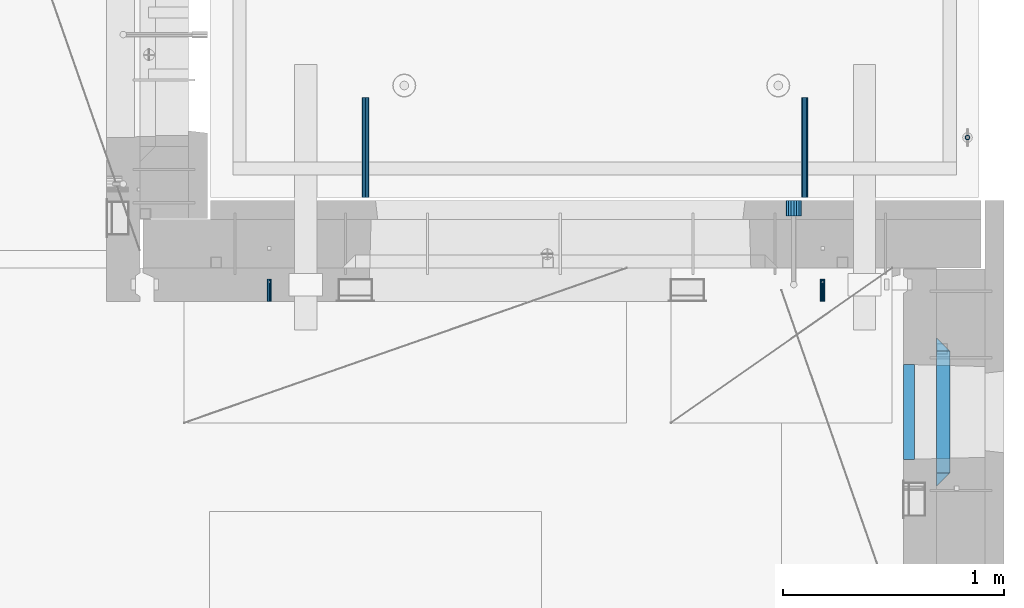
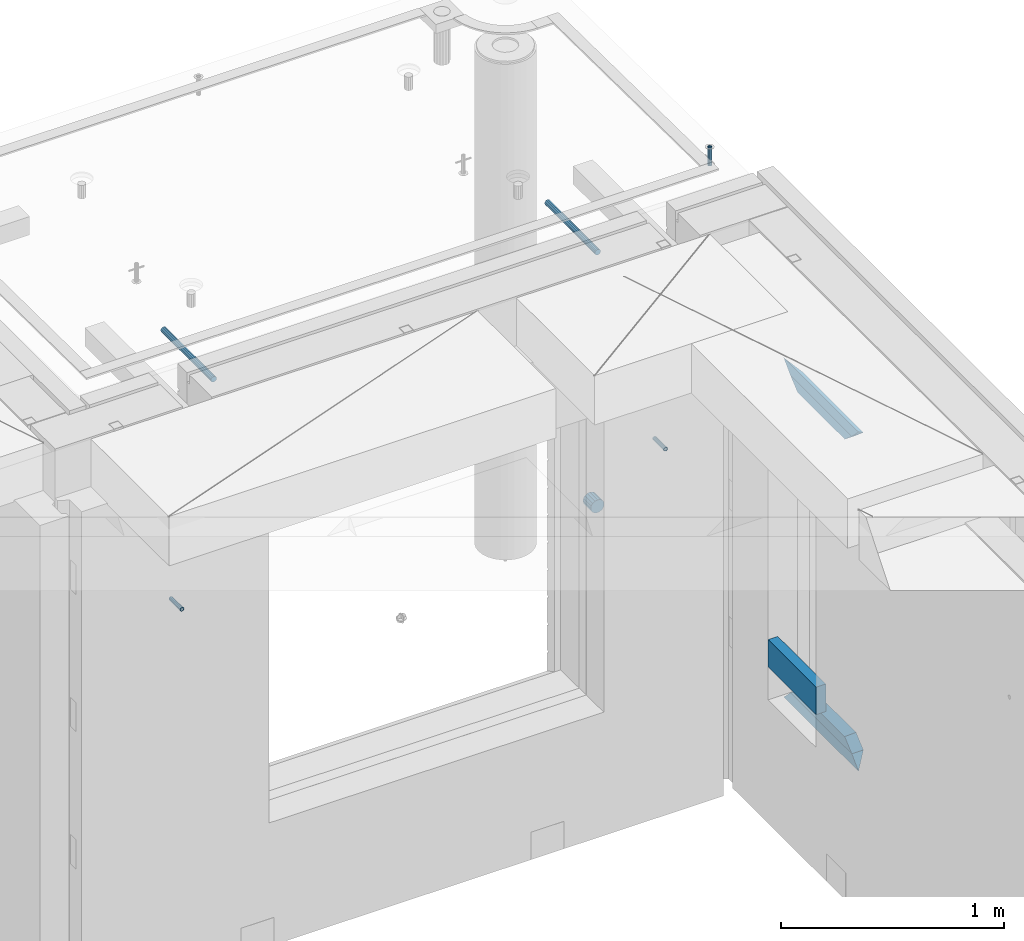
# One storey, part 170 of 349: 11 beams, 8 elements without a shape of their own.
"""IFC2X3 building model written with IfcOpenShell, lengths in millimetres."""

import ifcopenshell
import ifcopenshell.guid

model = None  # the IFC model being written
_history = None  # IfcOwnerHistory: only IFC2X3 demands one
_inside = {}  # id of a spatial element -> (the spatial element, [elements in it])
_under = {}  # id of a project, library or spatial element -> (it, [spatial elements below it])
_declared = {}  # id of a project -> (the project, [libraries it declares])
_typed = {}  # id of a type object -> (the type object, [elements of that type])
_made_of = {}  # id of a material, layer set ... -> (it, [elements and type objects made of it])


def new_model(schema):
    """Start an empty IFC model of exactly this schema.

    Asked for "IFC4X3", IfcOpenShell would pick the latest addendum, in which some entities
    have other attributes; the version numbers below select the first issue.
    IFC2X3 requires an IfcOwnerHistory on every rooted entity: one is made here for all.
    """
    global model, _history
    if schema == "IFC4X3":
        model = ifcopenshell.file(schema_version=(4, 3, 0, 0))
    else:
        model = ifcopenshell.file(schema=schema)
    _inside.clear()
    _under.clear()
    _declared.clear()
    _typed.clear()
    _made_of.clear()
    _history = None
    if model.schema == "IFC2X3":
        org = make("IfcOrganization", Name="unknown")
        user = make(
            "IfcPersonAndOrganization",
            ThePerson=make("IfcPerson", FamilyName="unknown"),
            TheOrganization=org,
        )
        app = make(
            "IfcApplication",
            ApplicationDeveloper=org,
            Version="unknown",
            ApplicationFullName="unknown",
            ApplicationIdentifier="unknown",
        )
        _history = make(
            "IfcOwnerHistory",
            OwningUser=user,
            OwningApplication=app,
            ChangeAction="ADDED",
            CreationDate=0,
        )
    return model


def make(cls, **values):
    """One entity of the class cls with the attributes given. An attribute that is None is left unset."""
    return model.create_entity(
        cls, **{name: value for name, value in values.items() if value is not None}
    )


def rooted(cls, **values):
    """An entity with a GlobalId (a new one), such as an element, a storey or a relation."""
    return make(cls, GlobalId=ifcopenshell.guid.new(), OwnerHistory=_history, **values)


def si_unit(unit_type, name, prefix=None):
    """IfcSIUnit, for example si_unit("LENGTHUNIT", "METRE", prefix="MILLI")."""
    return make("IfcSIUnit", UnitType=unit_type, Prefix=prefix, Name=name)


def assignment(units):
    """IfcUnitAssignment: the units of a project."""
    return None if units is None else make("IfcUnitAssignment", Units=units)


def point(xyz):
    """IfcCartesianPoint."""
    return None if xyz is None else make("IfcCartesianPoint", Coordinates=xyz)


def direction(xyz):
    """IfcDirection."""
    return None if xyz is None else make("IfcDirection", DirectionRatios=xyz)


def frame(location, z_axis=None, x_axis=None):
    """IfcAxis2Placement3D, a coordinate frame: its origin and axes. An axis left out is left unset."""
    return make(
        "IfcAxis2Placement3D",
        Location=point(location),
        Axis=direction(z_axis),
        RefDirection=direction(x_axis),
    )


def origin_with_axes():
    """The frame at (0, 0, 0) with the z axis (0, 0, 1) and the x axis (1, 0, 0) written out."""
    return frame((0.0, 0.0, 0.0), z_axis=(0.0, 0.0, 1.0), x_axis=(1.0, 0.0, 0.0))


def place(relative_to, where):
    """IfcLocalPlacement: puts the frame where relative to a parent placement (None: the world)."""
    return make(
        "IfcLocalPlacement", PlacementRelTo=relative_to, RelativePlacement=where
    )


def context(
    kind, dimensions, precision=None, world=None, true_north=None, identifier=None
):
    """IfcGeometricRepresentationContext, for example the 3D "Model" context."""
    return make(
        "IfcGeometricRepresentationContext",
        ContextIdentifier=identifier,
        ContextType=kind,
        CoordinateSpaceDimension=dimensions,
        Precision=precision,
        WorldCoordinateSystem=world,
        TrueNorth=true_north,
    )


def subcontext(parent, identifier, kind, view, scale=None):
    """IfcGeometricRepresentationSubContext, for example "Body" below "Model"."""
    return make(
        "IfcGeometricRepresentationSubContext",
        ContextIdentifier=identifier,
        ContextType=kind,
        ParentContext=parent,
        TargetScale=scale,
        TargetView=view,
    )


def project(units=None, contexts=None):
    """IfcProject with its units and contexts."""
    return rooted(
        "IfcProject",
        Name="project",
        RepresentationContexts=contexts,
        UnitsInContext=assignment(units),
    )


def spatial(cls, under=None, at=None, **own):
    """A site, building, storey or space (cls), placed at a placement, below another one or the project."""
    s = rooted(cls, ObjectPlacement=at, **own)
    if under is not None:
        _under.setdefault(under.id(), (under, []))[1].append(s)
    return s


def faces_of(points, faces, orient=None, outer=None):
    """IfcFace entities. A face is a list of loops; a loop is a list of indices into points, from 0.

    orient and outer hold one flag for each loop. By default every Orientation is true, the
    first loop of a face is its IfcFaceOuterBound and the others are IfcFaceBound.
    """
    made = []
    for i, loops in enumerate(faces):
        bounds = []
        for j, loop in enumerate(loops):
            is_outer = j == 0 if outer is None else outer[i][j]
            bounds.append(
                make(
                    "IfcFaceOuterBound" if is_outer else "IfcFaceBound",
                    Bound=make("IfcPolyLoop", Polygon=[points[k] for k in loop]),
                    Orientation=True if orient is None else orient[i][j],
                )
            )
        made.append(make("IfcFace", Bounds=bounds))
    return made


def faceted_brep(points, faces, orient=None, outer=None, voids=None):
    """IfcFacetedBrep: a solid bounded by flat faces; with voids (closed shells), ...WithVoids."""
    shared = [point(p) for p in points]
    hull = make("IfcClosedShell", CfsFaces=faces_of(shared, faces, orient, outer))
    if voids is None:
        return make("IfcFacetedBrep", Outer=hull)
    return make(
        "IfcFacetedBrepWithVoids",
        Outer=hull,
        Voids=[
            make(cls, CfsFaces=faces_of(shared, fs, o, b)) for cls, fs, o, b in voids
        ],
    )


def shape(context_of_items, identifier, shape_type, items):
    """IfcShapeRepresentation: the items that make up one representation, for example the "Body"."""
    return make(
        "IfcShapeRepresentation",
        ContextOfItems=context_of_items,
        RepresentationIdentifier=identifier,
        RepresentationType=shape_type,
        Items=items,
    )


def material(Name=None, Category=None):
    """IfcMaterial."""
    return make("IfcMaterial", Name=Name, Category=Category)


def made_of(thing, what):
    """Note that an element or type object is made of a material, layer set ...; save() writes the relation."""
    if what is not None:
        _made_of.setdefault(what.id(), (what, []))[1].append(thing)
    return thing


def type_object(cls, material=None, **own):
    """A type object (cls), such as IfcWallType, which elements share."""
    return made_of(rooted(cls, **own), material)


def element(
    cls,
    number,
    at=None,
    inside=None,
    cuts=None,
    type_object=None,
    material=None,
    context=None,
    identifier="Body",
    shape_type=None,
    held_by="IfcProductDefinitionShape",
    body=None,
    shapes=None,
    **own,
):
    """One element of the class cls, such as IfcWall. Its Tag is "e" and its number.

    at: its placement. inside: the storey or other place that contains it. cuts: it is an
    opening in that element (IfcRelVoidsElement). A single representation is given by context,
    identifier, shape_type and body (its items); several are given by shapes. held_by: the class
    of the entity that holds the representations. save() writes the other relations.
    """
    e = rooted(cls, Tag="e%d" % number, ObjectPlacement=at, **own)
    if body is not None:
        shapes = [shape(context, identifier, shape_type, body)]
    if shapes is not None:
        e.Representation = make(held_by, Representations=shapes)
    if inside is not None:
        _inside.setdefault(inside.id(), (inside, []))[1].append(e)
    if cuts is not None:
        rooted(
            "IfcRelVoidsElement", RelatingBuildingElement=cuts, RelatedOpeningElement=e
        )
    if type_object is not None:
        _typed.setdefault(type_object.id(), (type_object, []))[1].append(e)
    return made_of(e, material)


def aggregate(whole, parts):
    """IfcRelAggregates: a whole, such as a stair, and the parts it consists of."""
    return rooted("IfcRelAggregates", RelatingObject=whole, RelatedObjects=parts)


def save(model, path):
    """Write the relations noted so far, then the file.

    IfcRelAggregates (storeys below a building ...), IfcRelContainedInSpatialStructure (elements
    in a storey), IfcRelDefinesByType, IfcRelAssociatesMaterial and IfcRelDeclares: one each for
    every whole, place, type object, material and project.
    """
    for whole, parts in _under.values():
        aggregate(whole, parts)
    for where, things in _inside.values():
        rooted(
            "IfcRelContainedInSpatialStructure",
            RelatedElements=things,
            RelatingStructure=where,
        )
    for kind, things in _typed.values():
        rooted("IfcRelDefinesByType", RelatedObjects=things, RelatingType=kind)
    for what, things in _made_of.values():
        rooted("IfcRelAssociatesMaterial", RelatedObjects=things, RelatingMaterial=what)
    for by, libraries in _declared.values():
        rooted("IfcRelDeclares", RelatingContext=by, RelatedDefinitions=libraries)
    model.write(path)


model = new_model("IFC2X3")

# Units and contexts
model_context = context("Model", 3, precision=1e-05, world=origin_with_axes())
body_context = subcontext(model_context, "Body", "Model", "MODEL_VIEW")
ifc_project = project(units=[si_unit("LENGTHUNIT", "METRE", prefix="MILLI"), si_unit("AREAUNIT", "SQUARE_METRE"), si_unit("VOLUMEUNIT", "CUBIC_METRE"), si_unit("MASSUNIT", "GRAM", prefix="KILO"), si_unit("TIMEUNIT", "SECOND"), si_unit("PLANEANGLEUNIT", "RADIAN"), si_unit("SOLIDANGLEUNIT", "STERADIAN"), si_unit("THERMODYNAMICTEMPERATUREUNIT", "DEGREE_CELSIUS"), si_unit("LUMINOUSINTENSITYUNIT", "LUMEN")], contexts=[model_context])

# Site, building, storey
site_placement = place(None, origin_with_axes())
site = spatial("IfcSite", under=ifc_project, at=site_placement, CompositionType="ELEMENT")
building_placement = place(site_placement, origin_with_axes())
building = spatial("IfcBuilding", under=site, at=building_placement, CompositionType="ELEMENT")
storey_placement = place(building_placement, origin_with_axes())
storey = spatial("IfcBuildingStorey", under=building, at=storey_placement, Name="4", CompositionType="ELEMENT", Elevation=0.0)

# Assemblies, beams
assembly_1_placement = place(storey_placement, origin_with_axes())
assembly_1 = element("IfcElementAssembly", 1, at=assembly_1_placement, inside=storey, AssemblyPlace="NOTDEFINED", PredefinedType="REINFORCEMENT_UNIT")
assembly_2_placement = place(assembly_1_placement, origin_with_axes())
assembly_2 = element("IfcElementAssembly", 2, at=assembly_2_placement, Name="Steel Assembly", AssemblyPlace="NOTDEFINED", PredefinedType="RIGID_FRAME")
ifc_material_1 = material(Name="STEEL/Steel_Undefined")
beam_type_1 = type_object("IfcBeamType", PredefinedType="NOTDEFINED")
beam_1_placement = place(assembly_2_placement, frame((32044.9982931989, 20429.9951872276, 92755.0), z_axis=(1.0, 0.0, 0.0), x_axis=(0.0, 1.0, 0.0)))
beam_1 = element("IfcBeam", 3, at=beam_1_placement, type_object=beam_type_1, material=ifc_material_1, Name="M16", context=body_context, shape_type="Brep", body=[
    faceted_brep([(0.0, -8.49999999999272, -1.45519152283669e-11), (0.0, -7.36121593215648, 4.24999999998545), (100.000000000262, -7.36121593215648, 4.24999999998545), (100.000000000262, -8.49999999999272, -1.45519152283669e-11), (0.0, -4.24999999998545, 7.36121593216376), (100.000000000262, -4.24999999998545, 7.36121593216376), (0.0, 1.45519152283669e-11, 8.49999999998545), (100.000000000262, 1.45519152283669e-11, 8.49999999998545), (0.0, 4.25000000001455, 7.36121593216376), (100.000000000262, 4.25000000001455, 7.36121593216376), (0.0, 7.36121593217104, 4.24999999998545), (100.000000000262, 7.36121593217104, 4.24999999998545), (0.0, 8.50000000000728, 0.0), (100.000000000262, 8.50000000000728, 0.0), (0.0, 7.36121593217104, -4.25000000001455), (100.000000000262, 7.36121593217104, -4.25000000001455), (0.0, 4.25000000000728, -7.36121593219286), (100.000000000262, 4.25000000000728, -7.36121593219286), (0.0, 7.27595761418343e-12, -8.5), (100.000000000262, 7.27595761418343e-12, -8.5), (0.0, -4.24999999999272, -7.36121593217831), (100.000000000262, -4.24999999999272, -7.36121593217831), (0.0, -7.36121593215648, -4.25), (100.000000000262, -7.36121593215648, -4.25), (0.0, -10.4999999999927, -1.45519152283669e-11), (0.0, -9.09326673972828, -5.25000000001455), (100.000000000262, -9.09326673972828, -5.25000000001455), (100.000000000262, -10.4999999999927, -1.45519152283669e-11), (0.0, -5.24999999998545, -9.09326673974283), (100.000000000262, -5.24999999998545, -9.09326673974283), (0.0, 7.27595761418343e-12, -10.5), (100.000000000262, 7.27595761418343e-12, -10.5), (0.0, 5.25000000001455, -9.09326673975738), (100.000000000262, 5.25000000001455, -9.09326673975738), (0.0, 9.09326673975011, -5.25000000001455), (100.000000000262, 9.09326673975011, -5.25000000001455), (0.0, 10.5000000000073, -1.45519152283669e-11), (100.000000000262, 10.5000000000073, -1.45519152283669e-11), (0.0, 9.09326673975011, 5.25), (100.000000000262, 9.09326673975011, 5.25), (0.0, 5.25000000000728, 9.09326673972828), (100.000000000262, 5.25000000000728, 9.09326673972828), (0.0, 1.45519152283669e-11, 10.4999999999854), (100.000000000262, 1.45519152283669e-11, 10.4999999999854), (0.0, -5.24999999999272, 9.09326673972828), (100.000000000262, -5.24999999999272, 9.09326673972828), (0.0, -9.09326673972828, 5.24999999998545), (100.000000000262, -9.09326673972828, 5.24999999998545)], [[[0, 1, 2, 3]], [[1, 4, 5, 2]], [[4, 6, 7, 5]], [[6, 8, 9, 7]], [[8, 10, 11, 9]], [[10, 12, 13, 11]], [[12, 14, 15, 13]], [[14, 16, 17, 15]], [[16, 18, 19, 17]], [[18, 20, 21, 19]], [[20, 22, 23, 21]], [[22, 0, 3, 23]], [[24, 25, 26, 27]], [[25, 28, 29, 26]], [[28, 30, 31, 29]], [[30, 32, 33, 31]], [[32, 34, 35, 33]], [[34, 36, 37, 35]], [[36, 38, 39, 37]], [[38, 40, 41, 39]], [[40, 42, 43, 41]], [[42, 44, 45, 43]], [[44, 46, 47, 45]], [[46, 24, 27, 47]], [[29, 31, 33, 35, 37, 39, 41, 43, 45, 47, 27, 26], [5, 7, 9, 11, 13, 15, 17, 19, 21, 23, 3, 2]], [[46, 44, 42, 40, 38, 36, 34, 32, 30, 28, 25, 24], [22, 20, 18, 16, 14, 12, 10, 8, 6, 4, 1, 0]]]),
])
aggregate(assembly_2, [beam_1])
assembly_3_placement = place(assembly_1_placement, origin_with_axes())
assembly_3 = element("IfcElementAssembly", 4, at=assembly_3_placement, Name="Steel Assembly", AssemblyPlace="NOTDEFINED", PredefinedType="RIGID_FRAME")
beam_2_placement = place(assembly_3_placement, frame((34544.998293199, 20429.9951872276, 92755.0), z_axis=(1.0, 0.0, 0.0), x_axis=(0.0, 1.0, 0.0)))
beam_2 = element("IfcBeam", 5, at=beam_2_placement, type_object=beam_type_1, material=ifc_material_1, Name="M16", context=body_context, shape_type="Brep", body=[
    faceted_brep([(0.0, -8.49999999999272, -1.45519152283669e-11), (0.0, -7.36121593215648, 4.24999999998545), (100.000000000262, -7.36121593215648, 4.24999999998545), (100.000000000262, -8.49999999999272, -1.45519152283669e-11), (0.0, -4.24999999998545, 7.36121593216376), (100.000000000262, -4.24999999998545, 7.36121593216376), (0.0, 1.45519152283669e-11, 8.49999999998545), (100.000000000262, 1.45519152283669e-11, 8.49999999998545), (0.0, 4.25000000001455, 7.36121593216376), (100.000000000262, 4.25000000001455, 7.36121593216376), (0.0, 7.36121593217104, 4.24999999998545), (100.000000000262, 7.36121593217104, 4.24999999998545), (0.0, 8.50000000000728, 0.0), (100.000000000262, 8.50000000000728, 0.0), (0.0, 7.36121593217104, -4.25000000001455), (100.000000000262, 7.36121593217104, -4.25000000001455), (0.0, 4.25000000000728, -7.36121593219286), (100.000000000262, 4.25000000000728, -7.36121593219286), (0.0, 7.27595761418343e-12, -8.5), (100.000000000262, 7.27595761418343e-12, -8.5), (0.0, -4.24999999999272, -7.36121593217831), (100.000000000262, -4.24999999999272, -7.36121593217831), (0.0, -7.36121593215648, -4.25), (100.000000000262, -7.36121593215648, -4.25), (0.0, -10.4999999999927, -1.45519152283669e-11), (0.0, -9.09326673972828, -5.25000000001455), (100.000000000262, -9.09326673972828, -5.25000000001455), (100.000000000262, -10.4999999999927, -1.45519152283669e-11), (0.0, -5.24999999998545, -9.09326673974283), (100.000000000262, -5.24999999998545, -9.09326673974283), (0.0, 7.27595761418343e-12, -10.5), (100.000000000262, 7.27595761418343e-12, -10.5), (0.0, 5.25000000001455, -9.09326673975738), (100.000000000262, 5.25000000001455, -9.09326673975738), (0.0, 9.09326673975011, -5.25000000001455), (100.000000000262, 9.09326673975011, -5.25000000001455), (0.0, 10.5000000000073, -1.45519152283669e-11), (100.000000000262, 10.5000000000073, -1.45519152283669e-11), (0.0, 9.09326673975011, 5.25), (100.000000000262, 9.09326673975011, 5.25), (0.0, 5.25000000000728, 9.09326673972828), (100.000000000262, 5.25000000000728, 9.09326673972828), (0.0, 1.45519152283669e-11, 10.4999999999854), (100.000000000262, 1.45519152283669e-11, 10.4999999999854), (0.0, -5.24999999999272, 9.09326673972828), (100.000000000262, -5.24999999999272, 9.09326673972828), (0.0, -9.09326673972828, 5.24999999998545), (100.000000000262, -9.09326673972828, 5.24999999998545)], [[[0, 1, 2, 3]], [[1, 4, 5, 2]], [[4, 6, 7, 5]], [[6, 8, 9, 7]], [[8, 10, 11, 9]], [[10, 12, 13, 11]], [[12, 14, 15, 13]], [[14, 16, 17, 15]], [[16, 18, 19, 17]], [[18, 20, 21, 19]], [[20, 22, 23, 21]], [[22, 0, 3, 23]], [[24, 25, 26, 27]], [[25, 28, 29, 26]], [[28, 30, 31, 29]], [[30, 32, 33, 31]], [[32, 34, 35, 33]], [[34, 36, 37, 35]], [[36, 38, 39, 37]], [[38, 40, 41, 39]], [[40, 42, 43, 41]], [[42, 44, 45, 43]], [[44, 46, 47, 45]], [[46, 24, 27, 47]], [[29, 31, 33, 35, 37, 39, 41, 43, 45, 47, 27, 26], [5, 7, 9, 11, 13, 15, 17, 19, 21, 23, 3, 2]], [[46, 44, 42, 40, 38, 36, 34, 32, 30, 28, 25, 24], [22, 20, 18, 16, 14, 12, 10, 8, 6, 4, 1, 0]]]),
])
aggregate(assembly_3, [beam_2])

# Assemblies, beam
assembly_4_placement = place(storey_placement, origin_with_axes())
assembly_4 = element("IfcElementAssembly", 6, at=assembly_4_placement, inside=storey, AssemblyPlace="NOTDEFINED", PredefinedType="REINFORCEMENT_UNIT")
assembly_5_placement = place(assembly_4_placement, origin_with_axes())
assembly_5 = element("IfcElementAssembly", 7, at=assembly_5_placement, Name="Steel Assembly", AssemblyPlace="NOTDEFINED", PredefinedType="RIGID_FRAME")
ifc_material_2 = material(Name="STEEL/1.4301")
beam_type_2 = type_object("IfcBeamType", PredefinedType="NOTDEFINED")
beam_3_placement = place(assembly_5_placement, frame((35199.9998195516, 21170.0002421324, 93731.000000009), z_axis=(0.999999999984675, 3.40399999908427e-06, -4.36599999368485e-06), x_axis=(-4.36599999292741e-06, 0.0, -0.999999999990469)))
beam_3 = element("IfcBeam", 8, at=beam_3_placement, type_object=beam_type_2, material=ifc_material_2, context=body_context, shape_type="Brep", body=[
    faceted_brep([(0.0, -8.0, 0.0), (0.0, -6.92820323027263, 4.0), (100.000000000029, -6.92820323027263, 4.0), (100.000000000029, -7.99999999999636, 0.0), (0.0, -4.0, 6.92820323027627), (100.000000000029, -4.0, 6.92820323027536), (0.0, 0.0, 8.0), (100.000000000029, 3.63797880709171e-12, 8.0), (0.0, 4.0, 6.92820323027627), (100.000000000029, 4.0, 6.92820323027536), (0.0, 6.92820323027263, 4.0), (100.000000000029, 6.92820323027627, 3.99999999999909), (0.0, 8.0, 0.0), (100.000000000029, 8.0, 0.0), (0.0, 6.92820323027263, -4.0), (100.000000000029, 6.92820323027627, -4.00000000000091), (0.0, 4.0, -6.92820323027627), (100.000000000029, 4.00000000000364, -6.92820323027536), (0.0, 0.0, -8.0), (100.000000000029, 3.63797880709171e-12, -8.00000000000091), (0.0, -4.0, -6.92820323027627), (100.000000000029, -3.99999999999636, -6.92820323027627), (0.0, -6.92820323027263, -4.0), (100.000000000029, -6.92820323027263, -4.0), (0.0, -10.4999999999927, -1.45519152283669e-11), (0.0, -9.09326673972828, -5.25000000001455), (100.000000000262, -9.09326673972828, -5.25000000001455), (100.000000000262, -10.4999999999927, -1.45519152283669e-11), (0.0, -5.24999999998545, -9.09326673974283), (100.000000000262, -5.24999999998545, -9.09326673974283), (0.0, 7.27595761418343e-12, -10.5), (100.000000000262, 7.27595761418343e-12, -10.5), (0.0, 5.25000000001455, -9.09326673975738), (100.000000000262, 5.25000000001455, -9.09326673975738), (0.0, 9.09326673975011, -5.25000000001455), (100.000000000262, 9.09326673975011, -5.25000000001455), (0.0, 10.5000000000073, -1.45519152283669e-11), (100.000000000262, 10.5000000000073, -1.45519152283669e-11), (0.0, 9.09326673975011, 5.25), (100.000000000262, 9.09326673975011, 5.25), (0.0, 5.25000000000728, 9.09326673972828), (100.000000000262, 5.25000000000728, 9.09326673972828), (0.0, 1.45519152283669e-11, 10.4999999999854), (100.000000000262, 1.45519152283669e-11, 10.4999999999854), (0.0, -5.24999999999272, 9.09326673972828), (100.000000000262, -5.24999999999272, 9.09326673972828), (0.0, -9.09326673972828, 5.24999999998545), (100.000000000262, -9.09326673972828, 5.24999999998545)], [[[0, 1, 2, 3]], [[1, 4, 5, 2]], [[4, 6, 7, 5]], [[6, 8, 9, 7]], [[8, 10, 11, 9]], [[10, 12, 13, 11]], [[12, 14, 15, 13]], [[14, 16, 17, 15]], [[16, 18, 19, 17]], [[18, 20, 21, 19]], [[20, 22, 23, 21]], [[22, 0, 3, 23]], [[24, 25, 26, 27]], [[25, 28, 29, 26]], [[28, 30, 31, 29]], [[30, 32, 33, 31]], [[32, 34, 35, 33]], [[34, 36, 37, 35]], [[36, 38, 39, 37]], [[38, 40, 41, 39]], [[40, 42, 43, 41]], [[42, 44, 45, 43]], [[44, 46, 47, 45]], [[46, 24, 27, 47]], [[29, 31, 33, 35, 37, 39, 41, 43, 45, 47, 27, 26], [5, 7, 9, 11, 13, 15, 17, 19, 21, 23, 3, 2]], [[46, 44, 42, 40, 38, 36, 34, 32, 30, 28, 25, 24], [22, 20, 18, 16, 14, 12, 10, 8, 6, 4, 1, 0]]]),
])
aggregate(assembly_5, [beam_3])

# Beam
ifc_material_3 = material()
beam_type_3 = type_object("IfcBeamType", Name="D70", PredefinedType="NOTDEFINED")
beam_4_placement = place(assembly_1_placement, frame((34415.0, 20884.9951872276, 92255.0), z_axis=(0.0, 0.0, 1.0), x_axis=(0.0, -1.0, 0.0)))
beam_4 = element("IfcBeam", 9, at=beam_4_placement, type_object=beam_type_3, material=ifc_material_3, ObjectType="D70", context=body_context, shape_type="Brep", body=[
    faceted_brep([(0.0, -35.0, 0.0), (0.0, -32.3357836378964, -13.3939201327739), (70.0, -32.3357836378964, -13.3939201327739), (70.0, -35.0, 0.0), (0.0, -24.7487373415279, -24.7487373415352), (70.0, -24.7487373415279, -24.7487373415352), (0.0, -13.3939201327776, -32.3357836379), (70.0, -13.3939201327776, -32.3357836379), (0.0, 0.0, -35.0), (70.0, 0.0, -35.0), (0.0, 13.3939201327776, -32.3357836379), (70.0, 13.3939201327776, -32.3357836379), (0.0, 24.7487373415279, -24.7487373415352), (70.0, 24.7487373415279, -24.7487373415352), (0.0, 32.3357836378964, -13.3939201327739), (70.0, 32.3357836378964, -13.3939201327739), (0.0, 35.0, 0.0), (70.0, 35.0, 0.0), (0.0, 32.3357836378964, 13.3939201327739), (70.0, 32.3357836378964, 13.3939201327739), (0.0, 24.7487373415279, 24.7487373415352), (70.0, 24.7487373415279, 24.7487373415352), (0.0, 13.3939201327776, 32.3357836379), (70.0, 13.3939201327776, 32.3357836379), (0.0, 0.0, 35.0), (70.0, 0.0, 35.0), (0.0, -13.3939201327776, 32.3357836379), (70.0, -13.3939201327776, 32.3357836379), (0.0, -24.7487373415279, 24.7487373415352), (70.0, -24.7487373415279, 24.7487373415352), (0.0, -32.3357836378964, 13.3939201327739), (70.0, -32.3357836378964, 13.3939201327739)], [[[0, 1, 2, 3]], [[1, 4, 5, 2]], [[4, 6, 7, 5]], [[6, 8, 9, 7]], [[8, 10, 11, 9]], [[10, 12, 13, 11]], [[12, 14, 15, 13]], [[14, 16, 17, 15]], [[16, 18, 19, 17]], [[18, 20, 21, 19]], [[20, 22, 23, 21]], [[22, 24, 25, 23]], [[24, 26, 27, 25]], [[26, 28, 29, 27]], [[28, 30, 31, 29]], [[30, 0, 3, 31]], [[5, 7, 9, 11, 13, 15, 17, 19, 21, 23, 25, 27, 29, 31, 3, 2]], [[30, 28, 26, 24, 22, 20, 18, 16, 14, 12, 10, 8, 6, 4, 1, 0]]]),
])

aggregate(assembly_1, [assembly_2, assembly_3, beam_4])

# Assembly, beam
assembly_6_placement = place(assembly_4_placement, origin_with_axes())
assembly_6 = element("IfcElementAssembly", 10, at=assembly_6_placement, Name="Steel Assembly", AssemblyPlace="NOTDEFINED", PredefinedType="RIGID_FRAME")
ifc_material_4 = material(Name="STEEL/S235JR")
beam_type_4 = type_object("IfcBeamType", Name="D30", PredefinedType="NOTDEFINED")
beam_5_placement = place(assembly_6_placement, frame((32479.9998567563, 20900.0253394533, 93575.0), z_axis=(0.0, 0.0, 1.0), x_axis=(0.0, 1.0, 0.0)))
beam_5 = element("IfcBeam", 11, at=beam_5_placement, type_object=beam_type_4, material=ifc_material_4, Name="Rd30", ObjectType="D30", context=body_context, shape_type="Brep", body=[
    faceted_brep([(0.0, -15.0, 0.0), (0.0, -12.9903810567666, -7.5), (450.0, -12.9903810567666, -7.5), (450.0, -15.0, 0.0), (0.0, -7.5, -12.9903810567666), (450.0, -7.5, -12.990381056763), (0.0, 0.0, -15.0), (450.0, 0.0, -15.0), (0.0, 7.5, -12.9903810567666), (450.0, 7.5, -12.990381056763), (0.0, 12.9903810567666, -7.5), (450.0, 12.9903810567666, -7.5), (0.0, 15.0, 0.0), (450.0, 15.0, 0.0), (0.0, 12.9903810567666, 7.5), (450.0, 12.9903810567666, 7.5), (0.0, 7.5, 12.9903810567666), (450.0, 7.5, 12.990381056763), (0.0, 0.0, 15.0), (450.0, 0.0, 15.0), (0.0, -7.5, 12.9903810567666), (450.0, -7.5, 12.990381056763), (0.0, -12.9903810567666, 7.5), (450.0, -12.9903810567666, 7.5)], [[[0, 1, 2, 3]], [[1, 4, 5, 2]], [[4, 6, 7, 5]], [[6, 8, 9, 7]], [[8, 10, 11, 9]], [[10, 12, 13, 11]], [[12, 14, 15, 13]], [[14, 16, 17, 15]], [[16, 18, 19, 17]], [[18, 20, 21, 19]], [[20, 22, 23, 21]], [[22, 0, 3, 23]], [[5, 7, 9, 11, 13, 15, 17, 19, 21, 23, 3, 2]], [[22, 20, 18, 16, 14, 12, 10, 8, 6, 4, 1, 0]]]),
])
aggregate(assembly_6, [beam_5])

# Assembly
assembly_7_placement = place(assembly_4_placement, origin_with_axes())
assembly_7 = element("IfcElementAssembly", 12, at=assembly_7_placement, Name="Steel Assembly", AssemblyPlace="NOTDEFINED", PredefinedType="RIGID_FRAME")

aggregate(assembly_4, [assembly_5, assembly_6, assembly_7])

# Beam
beam_6_placement = place(assembly_7_placement, frame((34464.9998570066, 20900.0152136098, 93575.0), z_axis=(0.0, 0.0, 1.0), x_axis=(0.0, 1.0, 0.0)))
beam_6 = element("IfcBeam", 13, at=beam_6_placement, type_object=beam_type_4, material=ifc_material_4, Name="Rd30", ObjectType="D30", context=body_context, shape_type="Brep", body=[
    faceted_brep([(0.0, -15.0, 0.0), (0.0, -12.9903810567666, -7.5), (450.0, -12.9903810567666, -7.5), (450.0, -15.0, 0.0), (0.0, -7.5, -12.9903810567666), (450.0, -7.5, -12.990381056763), (0.0, 0.0, -15.0), (450.0, 0.0, -15.0), (0.0, 7.5, -12.9903810567666), (450.0, 7.5, -12.990381056763), (0.0, 12.9903810567666, -7.5), (450.0, 12.9903810567666, -7.5), (0.0, 15.0, 0.0), (450.0, 15.0, 0.0), (0.0, 12.9903810567666, 7.5), (450.0, 12.9903810567666, 7.5), (0.0, 7.5, 12.9903810567666), (450.0, 7.5, 12.990381056763), (0.0, 0.0, 15.0), (450.0, 0.0, 15.0), (0.0, -7.5, 12.9903810567666), (450.0, -7.5, 12.990381056763), (0.0, -12.9903810567666, 7.5), (450.0, -12.9903810567666, 7.5)], [[[0, 1, 2, 3]], [[1, 4, 5, 2]], [[4, 6, 7, 5]], [[6, 8, 9, 7]], [[8, 10, 11, 9]], [[10, 12, 13, 11]], [[12, 14, 15, 13]], [[14, 16, 17, 15]], [[16, 18, 19, 17]], [[18, 20, 21, 19]], [[20, 22, 23, 21]], [[22, 0, 3, 23]], [[5, 7, 9, 11, 13, 15, 17, 19, 21, 23, 3, 2]], [[22, 20, 18, 16, 14, 12, 10, 8, 6, 4, 1, 0]]]),
])

aggregate(assembly_7, [beam_6])

# Assembly, beams
assembly_8_placement = place(storey_placement, origin_with_axes())
assembly_8 = element("IfcElementAssembly", 14, at=assembly_8_placement, inside=storey, AssemblyPlace="NOTDEFINED", PredefinedType="REINFORCEMENT_UNIT")
ifc_material_5 = material(Name="TIMBER/T24")
beam_type_5 = type_object("IfcBeamType", PredefinedType="NOTDEFINED")
beam_7_placement = place(assembly_8_placement, frame((34935.0002758707, 19715.0011464907, 91685.0), z_axis=(0.0, 0.0, 1.0), x_axis=(0.0, 1.0, 0.0)))
beam_7 = element("IfcBeam", 15, at=beam_7_placement, type_object=beam_type_5, material=ifc_material_5, context=body_context, shape_type="Brep", body=[
    faceted_brep([(-3.63797880709171e-12, 24.9999999999964, -75.0), (-3.63797880709171e-12, 24.9999999999964, 75.0), (430.0, 25.0, 75.0), (430.0, 25.0, -75.0), (0.0, -25.0000000000073, 75.0), (430.0, -25.0, 75.0), (0.0, -25.0000000000073, -75.0), (430.0, -25.0, -75.0)], [[[0, 1, 2, 3]], [[1, 4, 5, 2]], [[4, 6, 7, 5]], [[6, 0, 3, 7]], [[5, 7, 3, 2]], [[6, 4, 1, 0]]]),
])
ifc_material_6 = material(Name="CONCRETE/C25/30")
beam_type_6 = type_object("IfcBeamType", PredefinedType="NOTDEFINED")
beam_8_placement = place(assembly_8_placement, frame((35090.0, 19595.0003479451, 93145.0), z_axis=(0.0, 0.0, -1.0), x_axis=(0.0, 1.0, 0.0)))
beam_8 = element("IfcBeam", 16, at=beam_8_placement, type_object=beam_type_6, material=ifc_material_6, Name="SK", context=body_context, shape_type="Brep", body=[
    faceted_brep([(60.0000000000073, 30.0, 30.0), (0.0, -30.0, -30.0), (60.0000000000073, -30.0, 30.0), (609.999618530263, 30.0, 30.0), (669.999575761092, -30.0, -30.0), (609.999618530263, -30.0, 30.0)], [[[0, 1, 2]], [[1, 0, 3, 4]], [[2, 1, 4, 5]], [[0, 2, 5, 3]], [[4, 3, 5]]]),
])
beam_9_placement = place(assembly_8_placement, frame((35090.0, 19655.0003479451, 93085.0), z_axis=(0.0, 0.0, -1.0), x_axis=(0.0, 1.0, 0.0)))
beam_9 = element("IfcBeam", 17, at=beam_9_placement, type_object=beam_type_6, material=ifc_material_6, Name="SK", context=body_context, shape_type="Brep", body=[
    faceted_brep([(65.6752942059502, 30.0, 25.6756756756804), (64.0536725843267, -30.0, 24.0540540540533), (485.94556447622, -30.0, 24.0540540540533), (484.323942854597, 30.0, 25.6756756756804), (65.6752942059502, 30.0, 26.293109307022), (64.0536725843267, -30.0, 24.9031479173718), (0.0, -30.0, -30.0), (0.0, 30.0, -30.0), (549.999575761092, 29.999999998452, -30.0), (549.999575761092, -29.999999998452, -30.0), (485.94556447622, -30.0, 24.9034748914273), (484.323942854597, 30.0, 26.293436281092)], [[[0, 1, 2, 3]], [[1, 0, 4, 5]], [[6, 5, 4, 7]], [[6, 7, 8, 9]], [[2, 1, 5, 6, 9, 10]], [[3, 2, 10, 11]], [[7, 4, 0, 3, 11, 8]], [[10, 9, 8, 11]]]),
])
beam_10_placement = place(assembly_8_placement, frame((35090.0, 20264.9999664753, 91350.0), z_axis=(0.0, 0.0, 1.0), x_axis=(0.0, -1.0, 0.0)))
beam_10 = element("IfcBeam", 18, at=beam_10_placement, type_object=beam_type_6, material=ifc_material_6, Name="SK", context=body_context, shape_type="Brep", body=[
    faceted_brep([(669.999575761092, -30.0, -30.0), (609.999618530263, 30.0, 30.0), (609.999618530263, -30.0, 30.0), (60.0000000000073, 30.0, 30.0), (60.0000000000073, -30.0, 30.0), (0.0, -30.0, -30.0)], [[[0, 1, 2]], [[3, 4, 2, 1]], [[4, 5, 0, 2]], [[5, 3, 1, 0]], [[3, 5, 4]]]),
])
beam_11_placement = place(assembly_8_placement, frame((35090.0, 20204.9999664753, 91410.0), z_axis=(0.0, 0.0, 1.0), x_axis=(0.0, -1.0, 0.0)))
beam_11 = element("IfcBeam", 19, at=beam_11_placement, type_object=beam_type_6, material=ifc_material_6, Name="SK", context=body_context, shape_type="Brep", body=[
    faceted_brep([(485.945945945947, -30.0, 24.0540540540533), (484.324324324325, 30.0, 25.6756756756804), (65.6756756756768, 30.0, 25.6756756756804), (64.0540540540533, -30.0, 24.0540540540533), (485.945945945947, -30.0, 24.9031479173718), (484.324324324323, 30.0, 26.2931093070365), (549.999575761092, -29.999999998452, -30.0), (549.999575761092, 29.999999998452, -30.0), (0.0, 30.0, -30.0), (65.6756756756768, 30.0, 26.293436281092), (64.0540540540533, -30.0, 24.9034748914419), (0.0, -30.0, -30.0)], [[[0, 1, 2, 3]], [[1, 0, 4, 5]], [[6, 7, 5, 4]], [[2, 1, 5, 7, 8, 9]], [[3, 2, 9, 10]], [[6, 4, 0, 3, 10, 11]], [[11, 8, 7, 6]], [[11, 10, 9, 8]]]),
])
aggregate(assembly_8, [beam_7, beam_8, beam_9, beam_10, beam_11])

save(model, "model.ifc")
